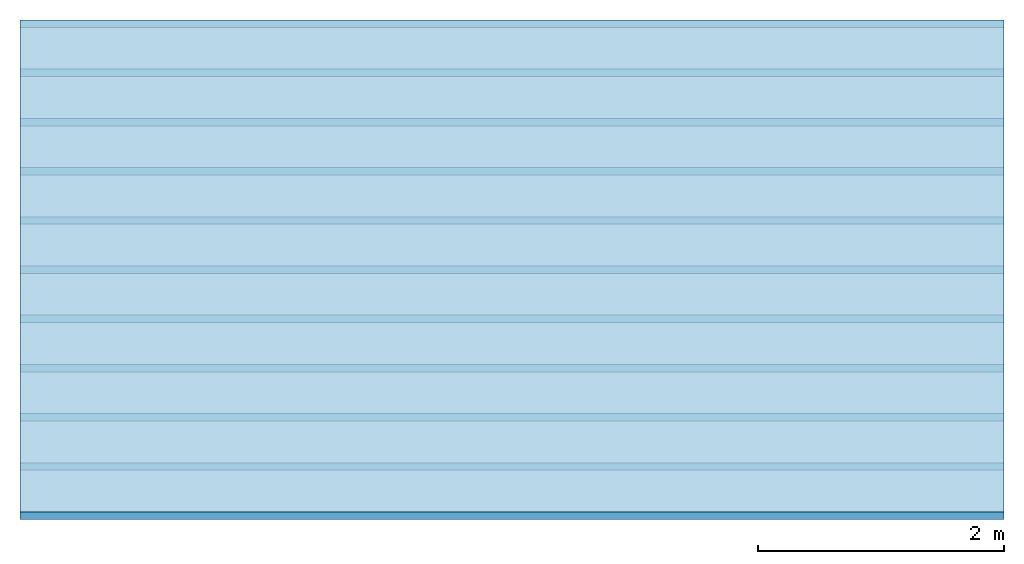
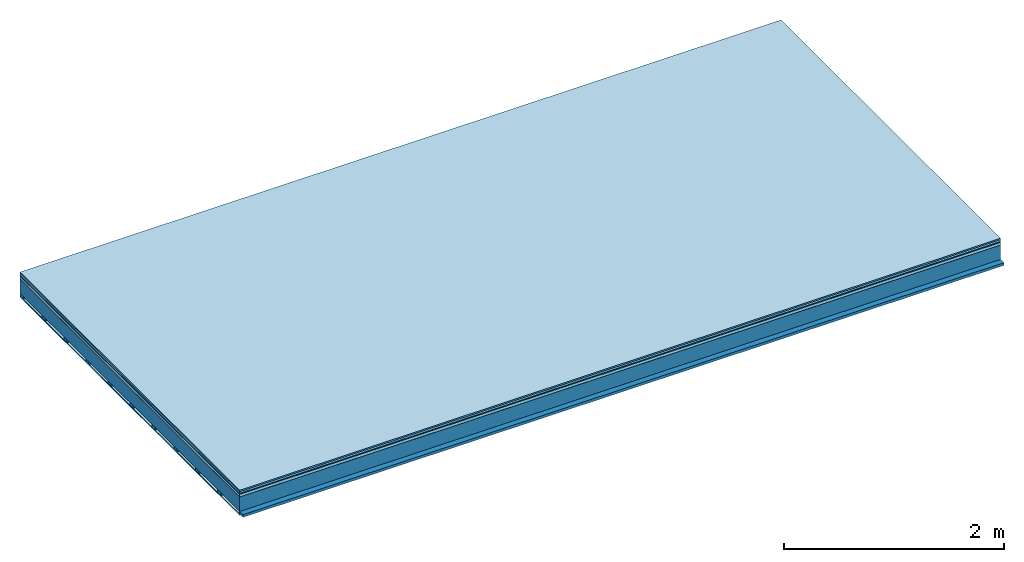
# One storey: 7 plates, 2 members, 1 element without a shape of its own.
"""IFC4 building model written with IfcOpenShell, lengths in metres."""

from ifc_helpers import new_model, si_unit, derived_unit, direction, frame, frame_2d, origin, origin_with_axes, place, context, project, spatial, rectangle, extrude, material, layer, layer_set, type_object, element, aggregate, save


model = new_model("IFC4")

# Units and contexts
plan_context = context("Plan", 3, precision=1e-05, world=origin(), true_north=direction((0.0, 1.0)))
model_context = context("Model", 3, precision=1e-05, world=origin(), true_north=direction((0.0, 1.0)))
ifc_project = project(units=[si_unit("LENGTHUNIT", "METRE"), derived_unit("SOUNDPRESSUREUNIT", [(si_unit("PRESSUREUNIT", "PASCAL", prefix="MICRO"), 0)]), si_unit("ENERGYUNIT", "JOULE", prefix="MEGA"), si_unit("MASSUNIT", "GRAM", prefix="KILO"), derived_unit("THERMALTRANSMITTANCEUNIT", [(si_unit("POWERUNIT", "WATT"), 1), (si_unit("AREAUNIT", "SQUARE_METRE"), -1), (si_unit("THERMODYNAMICTEMPERATUREUNIT", "KELVIN"), -1)]), derived_unit("AREADENSITYUNIT", [(si_unit("MASSUNIT", "GRAM", prefix="KILO"), 1), (si_unit("AREAUNIT", "SQUARE_METRE"), -1)]), derived_unit("USERDEFINED", [(si_unit("ENERGYUNIT", "JOULE", prefix="MEGA"), 1), (si_unit("AREAUNIT", "SQUARE_METRE"), -1)])], contexts=[plan_context, model_context])

# Site, building, storey
site = spatial("IfcSite", under=ifc_project)
building_placement = place(None, origin())
building = spatial("IfcBuilding", under=site, at=building_placement)
storey_placement = place(building_placement, origin())
storey = spatial("IfcBuildingStorey", under=building, at=storey_placement)

# Slab, members, plates
ifc_material_1 = material(Category="11.013")
ifc_layer_1 = layer(ifc_material_1, 0.015, Name="Flooring")
ifc_material_2 = material(Category="03.007")
ifc_layer_2 = layer(ifc_material_2, 0.02, Name="On-material")
ifc_material_3 = material(Name="Wood fiber generic product", Category="10.009")
ifc_layer_3 = layer(ifc_material_3, 0.01, Name="Impact sound insulation")
ifc_material_4 = material(Name="with broken")
ifc_layer_4 = layer(ifc_material_4, 0.03, Name="on Supporting structure")
ifc_material_5 = material(Name="protection", Category="09.007")
ifc_layer_5 = layer(ifc_material_5, 0.0005, Name="Sub-floor")
ifc_material_6 = material(Name="no composite action")
ifc_layer_6 = layer(ifc_material_6, 0.0, Name="Bond")
ifc_layer_7 = layer(None, 0.16, Name="Supporting structure")
ifc_material_7 = material(Name="of the art")
ifc_layer_8 = layer(ifc_material_7, 0.0, Name="Bond")
ifc_layer_9 = layer(None, 0.03, Name="Battens / profiles")
ifc_material_8 = material(Name="Plasterboard type A", Category="03.008")
ifc_layer_10 = layer(ifc_material_8, 0.0125, Name="Ceiling covering 1st layer")
ifc_material_9 = material(Category="04.001")
ifc_layer_11 = layer(ifc_material_9, 0.003, Name="Surface / treatment")
ifc_layer_set = layer_set([ifc_layer_1, ifc_layer_2, ifc_layer_3, ifc_layer_4, ifc_layer_5, ifc_layer_6, ifc_layer_7, ifc_layer_8, ifc_layer_9, ifc_layer_10, ifc_layer_11])
slab_type = type_object("IfcSlabType", Name="A2107", PredefinedType="NOTDEFINED", material=ifc_layer_set)
slab_placement = place(None, frame((0.0, 0.0, 0.0), z_axis=(0.0, 0.0, -1.0), x_axis=(1.0, 0.0, 0.0)))
slab = element("IfcSlab", 1, at=slab_placement, inside=storey, type_object=slab_type, material=ifc_layer_set, Name="Slab #1")
ifc_material_10 = material(Name="Solid timber panel")
member_1_placement = place(slab_placement, origin())
member_1 = element("IfcMember", 2, at=member_1_placement, material=ifc_material_10, Name="Supporting structure", context=plan_context, shape_type="SweptSolid", body=[
    extrude(rectangle(XDim=1.0, YDim=0.16, at=frame_2d((0.5, 0.08), x_axis=(1.0, 0.0))), frame((0.0, 4.0, 0.0755), z_axis=(0.0, -1.0, 0.0), x_axis=(1.0, 0.0, 0.0)), (0.0, 0.0, 1.0), 4.0),
    extrude(rectangle(XDim=1.0, YDim=0.16, at=frame_2d((0.5, 0.08), x_axis=(1.0, 0.0))), frame((1.0, 4.0, 0.0755), z_axis=(0.0, -1.0, 0.0), x_axis=(1.0, 0.0, 0.0)), (0.0, 0.0, 1.0), 4.0),
    extrude(rectangle(XDim=1.0, YDim=0.16, at=frame_2d((0.5, 0.08), x_axis=(1.0, 0.0))), frame((2.0, 4.0, 0.0755), z_axis=(0.0, -1.0, 0.0), x_axis=(1.0, 0.0, 0.0)), (0.0, 0.0, 1.0), 4.0),
    extrude(rectangle(XDim=1.0, YDim=0.16, at=frame_2d((0.5, 0.08), x_axis=(1.0, 0.0))), frame((3.0, 4.0, 0.0755), z_axis=(0.0, -1.0, 0.0), x_axis=(1.0, 0.0, 0.0)), (0.0, 0.0, 1.0), 4.0),
    extrude(rectangle(XDim=1.0, YDim=0.16, at=frame_2d((0.5, 0.08), x_axis=(1.0, 0.0))), frame((4.0, 4.0, 0.0755), z_axis=(0.0, -1.0, 0.0), x_axis=(1.0, 0.0, 0.0)), (0.0, 0.0, 1.0), 4.0),
    extrude(rectangle(XDim=1.0, YDim=0.16, at=frame_2d((0.5, 0.08), x_axis=(1.0, 0.0))), frame((5.0, 4.0, 0.0755), z_axis=(0.0, -1.0, 0.0), x_axis=(1.0, 0.0, 0.0)), (0.0, 0.0, 1.0), 4.0),
    extrude(rectangle(XDim=1.0, YDim=0.16, at=frame_2d((0.5, 0.08), x_axis=(1.0, 0.0))), frame((6.0, 4.0, 0.0755), z_axis=(0.0, -1.0, 0.0), x_axis=(1.0, 0.0, 0.0)), (0.0, 0.0, 1.0), 4.0),
    extrude(rectangle(XDim=1.0, YDim=0.16, at=frame_2d((0.5, 0.08), x_axis=(1.0, 0.0))), frame((7.0, 4.0, 0.0755), z_axis=(0.0, -1.0, 0.0), x_axis=(1.0, 0.0, 0.0)), (0.0, 0.0, 1.0), 4.0),
])
ifc_material_11 = material()
member_2_placement = place(slab_placement, origin())
member_2 = element("IfcMember", 3, at=member_2_placement, material=ifc_material_11, Name="Battens / profiles", context=plan_context, shape_type="SweptSolid", body=[
    extrude(rectangle(XDim=0.06, YDim=0.03, at=frame_2d((0.03, 0.015), x_axis=(1.0, 0.0))), frame((0.0, 0.0, 0.2355), z_axis=(1.0, 0.0, 0.0), x_axis=(0.0, 1.0, 0.0)), (0.0, 0.0, 1.0), 8.0),
    extrude(rectangle(XDim=0.06, YDim=0.03, at=frame_2d((0.03, 0.015), x_axis=(1.0, 0.0))), frame((0.0, 0.4, 0.2355), z_axis=(1.0, 0.0, 0.0), x_axis=(0.0, 1.0, 0.0)), (0.0, 0.0, 1.0), 8.0),
    extrude(rectangle(XDim=0.06, YDim=0.03, at=frame_2d((0.03, 0.015), x_axis=(1.0, 0.0))), frame((0.0, 0.8, 0.2355), z_axis=(1.0, 0.0, 0.0), x_axis=(0.0, 1.0, 0.0)), (0.0, 0.0, 1.0), 8.0),
    extrude(rectangle(XDim=0.06, YDim=0.03, at=frame_2d((0.03, 0.015), x_axis=(1.0, 0.0))), frame((0.0, 1.2, 0.2355), z_axis=(1.0, 0.0, 0.0), x_axis=(0.0, 1.0, 0.0)), (0.0, 0.0, 1.0), 8.0),
    extrude(rectangle(XDim=0.06, YDim=0.03, at=frame_2d((0.03, 0.015), x_axis=(1.0, 0.0))), frame((0.0, 1.6, 0.2355), z_axis=(1.0, 0.0, 0.0), x_axis=(0.0, 1.0, 0.0)), (0.0, 0.0, 1.0), 8.0),
    extrude(rectangle(XDim=0.06, YDim=0.03, at=frame_2d((0.03, 0.015), x_axis=(1.0, 0.0))), frame((0.0, 2.0, 0.2355), z_axis=(1.0, 0.0, 0.0), x_axis=(0.0, 1.0, 0.0)), (0.0, 0.0, 1.0), 8.0),
    extrude(rectangle(XDim=0.06, YDim=0.03, at=frame_2d((0.03, 0.015), x_axis=(1.0, 0.0))), frame((0.0, 2.4, 0.2355), z_axis=(1.0, 0.0, 0.0), x_axis=(0.0, 1.0, 0.0)), (0.0, 0.0, 1.0), 8.0),
    extrude(rectangle(XDim=0.06, YDim=0.03, at=frame_2d((0.03, 0.015), x_axis=(1.0, 0.0))), frame((0.0, 2.8, 0.2355), z_axis=(1.0, 0.0, 0.0), x_axis=(0.0, 1.0, 0.0)), (0.0, 0.0, 1.0), 8.0),
    extrude(rectangle(XDim=0.06, YDim=0.03, at=frame_2d((0.03, 0.015), x_axis=(1.0, 0.0))), frame((0.0, 3.2, 0.2355), z_axis=(1.0, 0.0, 0.0), x_axis=(0.0, 1.0, 0.0)), (0.0, 0.0, 1.0), 8.0),
    extrude(rectangle(XDim=0.06, YDim=0.03, at=frame_2d((0.03, 0.015), x_axis=(1.0, 0.0))), frame((0.0, 3.6, 0.2355), z_axis=(1.0, 0.0, 0.0), x_axis=(0.0, 1.0, 0.0)), (0.0, 0.0, 1.0), 8.0),
    extrude(rectangle(XDim=0.06, YDim=0.03, at=frame_2d((0.03, 0.015), x_axis=(1.0, 0.0))), frame((0.0, 4.0, 0.2355), z_axis=(1.0, 0.0, 0.0), x_axis=(0.0, 1.0, 0.0)), (0.0, 0.0, 1.0), 8.0),
])
plate_1_placement = place(slab_placement, origin())
plate_1 = element("IfcPlate", 4, at=plate_1_placement, material=ifc_material_1, Name="Flooring", context=plan_context, shape_type="SweptSolid", body=[
    extrude(rectangle(XDim=8.0, YDim=4.0, at=frame_2d((4.0, 2.0), x_axis=(1.0, 0.0))), origin_with_axes(), (0.0, 0.0, 1.0), 0.015),
])
plate_2_placement = place(slab_placement, origin())
plate_2 = element("IfcPlate", 5, at=plate_2_placement, material=ifc_material_2, Name="On-material", context=plan_context, shape_type="SweptSolid", body=[
    extrude(rectangle(XDim=8.0, YDim=4.0, at=frame_2d((4.0, 2.0), x_axis=(1.0, 0.0))), frame((0.0, 0.0, 0.015), z_axis=(0.0, 0.0, 1.0), x_axis=(1.0, 0.0, 0.0)), (0.0, 0.0, 1.0), 0.02),
])
plate_3_placement = place(slab_placement, origin())
plate_3 = element("IfcPlate", 6, at=plate_3_placement, material=ifc_material_3, Name="Impact sound insulation", context=plan_context, shape_type="SweptSolid", body=[
    extrude(rectangle(XDim=8.0, YDim=4.0, at=frame_2d((4.0, 2.0), x_axis=(1.0, 0.0))), frame((0.0, 0.0, 0.035), z_axis=(0.0, 0.0, 1.0), x_axis=(1.0, 0.0, 0.0)), (0.0, 0.0, 1.0), 0.01),
])
plate_4_placement = place(slab_placement, origin())
plate_4 = element("IfcPlate", 7, at=plate_4_placement, material=ifc_material_4, Name="on Supporting structure", context=plan_context, shape_type="SweptSolid", body=[
    extrude(rectangle(XDim=8.0, YDim=4.0, at=frame_2d((4.0, 2.0), x_axis=(1.0, 0.0))), frame((0.0, 0.0, 0.045), z_axis=(0.0, 0.0, 1.0), x_axis=(1.0, 0.0, 0.0)), (0.0, 0.0, 1.0), 0.03),
])
plate_5_placement = place(slab_placement, origin())
plate_5 = element("IfcPlate", 8, at=plate_5_placement, material=ifc_material_5, Name="Sub-floor", context=plan_context, shape_type="SweptSolid", body=[
    extrude(rectangle(XDim=8.0, YDim=4.0, at=frame_2d((4.0, 2.0), x_axis=(1.0, 0.0))), frame((0.0, 0.0, 0.075), z_axis=(0.0, 0.0, 1.0), x_axis=(1.0, 0.0, 0.0)), (0.0, 0.0, 1.0), 0.0005),
])
plate_6_placement = place(slab_placement, origin())
plate_6 = element("IfcPlate", 9, at=plate_6_placement, material=ifc_material_8, Name="Ceiling covering 1st layer", context=plan_context, shape_type="SweptSolid", body=[
    extrude(rectangle(XDim=8.0, YDim=4.0, at=frame_2d((4.0, 2.0), x_axis=(1.0, 0.0))), frame((0.0, 0.0, 0.2655), z_axis=(0.0, 0.0, 1.0), x_axis=(1.0, 0.0, 0.0)), (0.0, 0.0, 1.0), 0.0125),
])
plate_7_placement = place(slab_placement, origin())
plate_7 = element("IfcPlate", 10, at=plate_7_placement, material=ifc_material_9, Name="Surface / treatment", context=plan_context, shape_type="SweptSolid", body=[
    extrude(rectangle(XDim=8.0, YDim=4.0, at=frame_2d((4.0, 2.0), x_axis=(1.0, 0.0))), frame((0.0, 0.0, 0.278), z_axis=(0.0, 0.0, 1.0), x_axis=(1.0, 0.0, 0.0)), (0.0, 0.0, 1.0), 0.003),
])
aggregate(slab, [plate_1, plate_2, plate_3, plate_4, plate_5, member_1, member_2, plate_6, plate_7])

save(model, "model.ifc")
